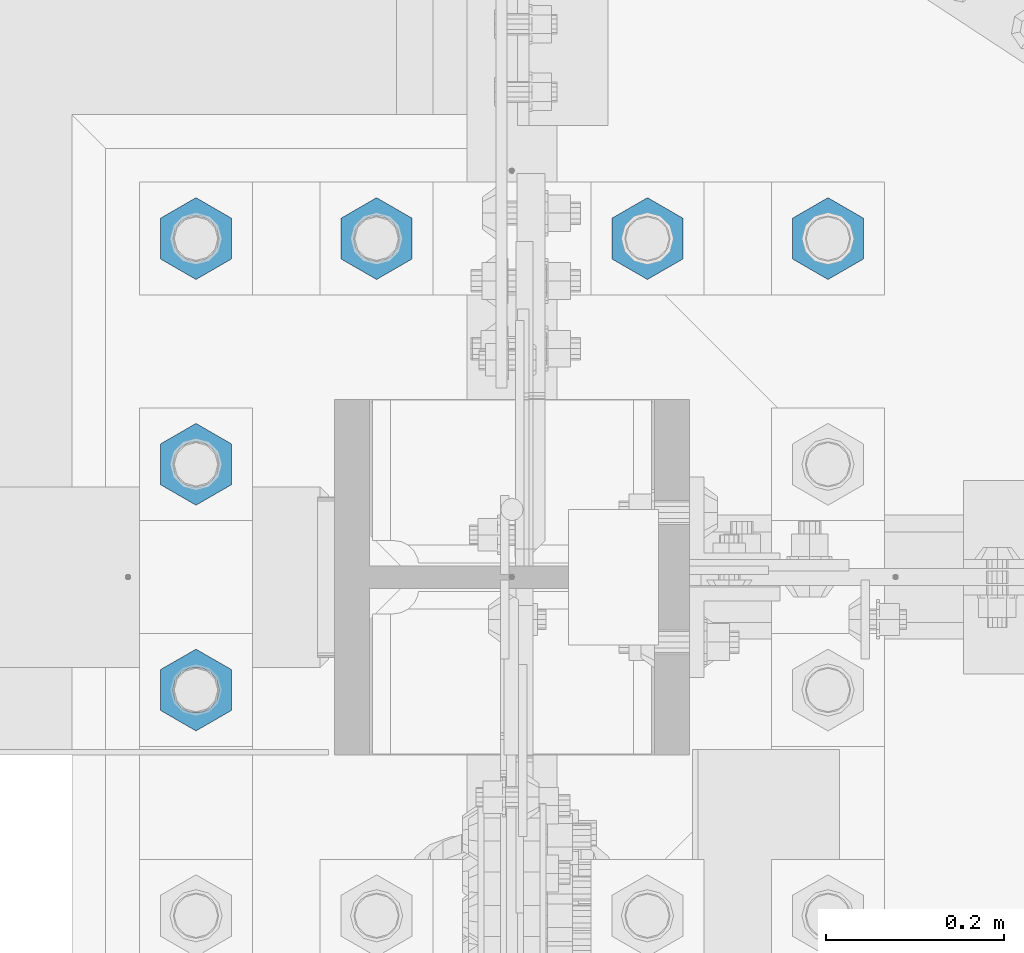
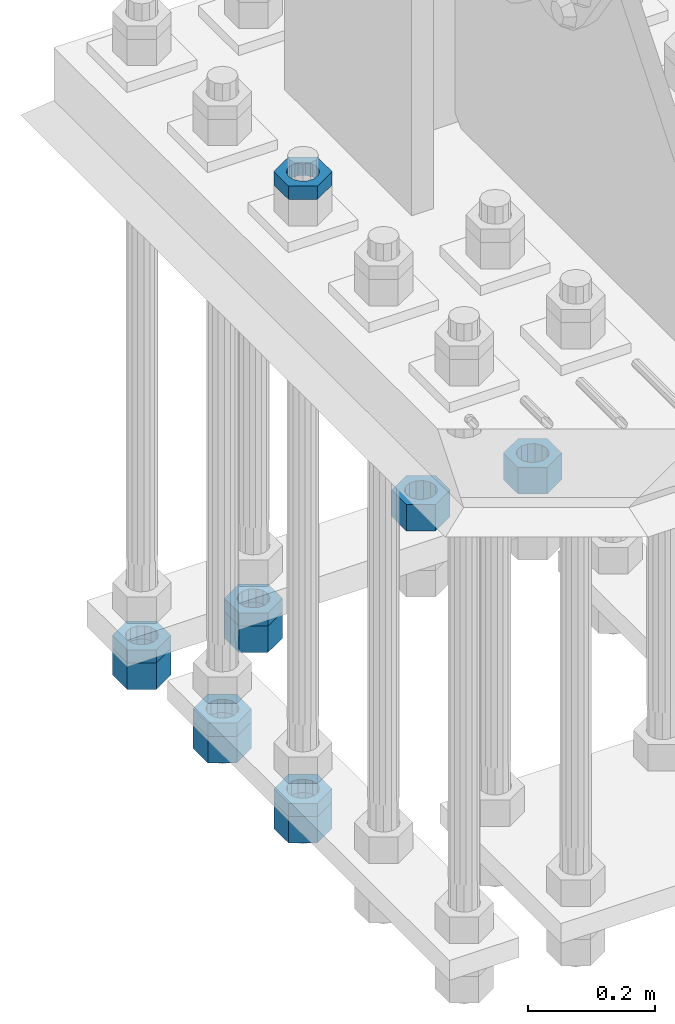
# One storey, part 2215 of 3843: 11 beams, 1 element without a shape of its own.
"""IFC2X3 building model written with IfcOpenShell, lengths in millimetres."""

from ifc_helpers import new_model, si_unit, frame, origin_with_axes, place, context, subcontext, project, spatial, faceted_brep, material, type_object, element, aggregate, save


model = new_model("IFC2X3")

# Units and contexts
model_context = context("Model", 3, precision=1e-05, world=origin_with_axes())
body_context = subcontext(model_context, "Body", "Model", "MODEL_VIEW")
ifc_project = project(units=[si_unit("LENGTHUNIT", "METRE", prefix="MILLI"), si_unit("AREAUNIT", "SQUARE_METRE"), si_unit("VOLUMEUNIT", "CUBIC_METRE"), si_unit("MASSUNIT", "GRAM", prefix="KILO"), si_unit("TIMEUNIT", "SECOND"), si_unit("PLANEANGLEUNIT", "RADIAN"), si_unit("SOLIDANGLEUNIT", "STERADIAN"), si_unit("THERMODYNAMICTEMPERATUREUNIT", "DEGREE_CELSIUS"), si_unit("LUMINOUSINTENSITYUNIT", "LUMEN")], contexts=[model_context])

# Site, building, storey
site_placement = place(None, origin_with_axes())
site = spatial("IfcSite", under=ifc_project, at=site_placement, CompositionType="ELEMENT")
building_placement = place(site_placement, origin_with_axes())
building = spatial("IfcBuilding", under=site, at=building_placement, Name="Undefined", CompositionType="ELEMENT")
storey_placement = place(building_placement, origin_with_axes())
storey = spatial("IfcBuildingStorey", under=building, at=storey_placement, Name="Undefined", CompositionType="ELEMENT", Elevation=0.0)

# Assembly, beams
assembly_placement = place(storey_placement, origin_with_axes())
assembly = element("IfcElementAssembly", 1, at=assembly_placement, inside=storey, Name="TEMPLATE", AssemblyPlace="NOTDEFINED", PredefinedType="RIGID_FRAME")
ifc_material = material(Name="STEEL/A572-50")
beam_type_1 = type_object("IfcBeamType", Name="2_HALF_NUT", PredefinedType="NOTDEFINED")
beam_1_placement = place(assembly_placement, frame((36220.4, 58788.3, 30257.75), z_axis=(1.0, 0.0, 0.0), x_axis=(0.0, 0.0, -1.0)))
beam_1 = element("IfcBeam", 2, at=beam_1_placement, type_object=beam_type_1, material=ifc_material, Name="NUT", ObjectType="2_HALF_NUT", context=body_context, shape_type="Brep", body=[
    faceted_brep([(0.0, -46.0369987487793, 0.0), (0.0, -23.0184993743896, -39.869213104248), (25.4000000000015, -23.0184993743896, -39.869213104248), (25.4000000000015, -46.0369987487793, 0.0), (0.0, 23.0184993743896, -39.869213104248), (25.4000000000015, 23.0184993743896, -39.869213104248), (0.0, 46.0369987487793, 0.0), (25.4000000000015, 46.0369987487793, 0.0), (0.0, 23.0184993743896, 39.869213104248), (25.4000000000015, 23.0184993743896, 39.869213104248), (0.0, -23.0184993743896, 39.869213104248), (25.4000000000015, -23.0184993743896, 39.869213104248), (0.0, 0.0, 26.1940002441406), (0.0, 11.3650617044477, 23.5999013092805), (25.4000000000015, 11.3650617044477, 23.5999013092805), (25.4000000000015, 0.0, 26.1940002441406), (0.0, 20.4791109456419, 16.3316083006721), (25.4000000000015, 20.4791109456419, 16.3316083006721), (0.0, 25.5370200498292, 5.82867859874386), (25.4000000000015, 25.5370200498292, 5.82867859874386), (0.0, 25.5370200498292, -5.82867859874386), (25.4000000000015, 25.5370200498292, -5.82867859874386), (0.0, 20.4791109456419, -16.3316083006721), (25.4000000000015, 20.4791109456419, -16.3316083006721), (0.0, 11.3650617044477, -23.5999013092805), (25.4000000000015, 11.3650617044477, -23.5999013092805), (0.0, 0.0, -26.1940002441406), (25.4000000000015, 0.0, -26.1940002441406), (0.0, -11.3650617044477, -23.5999013092805), (25.4000000000015, -11.3650617044477, -23.5999013092805), (0.0, -20.4791109456419, -16.3316083006721), (25.4000000000015, -20.4791109456419, -16.3316083006721), (0.0, -25.5370200498292, -5.82867859874386), (25.4000000000015, -25.5370200498292, -5.82867859874386), (0.0, -25.5370200498292, 5.82867859874386), (25.4000000000015, -25.5370200498292, 5.82867859874386), (0.0, -20.4791109456419, 16.3316083006721), (25.4000000000015, -20.4791109456419, 16.3316083006721), (0.0, -11.3650617044477, 23.5999013092805), (25.4000000000015, -11.3650617044477, 23.5999013092805)], [[[0, 1, 2, 3]], [[1, 4, 5, 2]], [[4, 6, 7, 5]], [[6, 8, 9, 7]], [[8, 10, 11, 9]], [[10, 0, 3, 11]], [[12, 13, 14, 15]], [[13, 16, 17, 14]], [[16, 18, 19, 17]], [[18, 20, 21, 19]], [[20, 22, 23, 21]], [[22, 24, 25, 23]], [[24, 26, 27, 25]], [[26, 28, 29, 27]], [[28, 30, 31, 29]], [[30, 32, 33, 31]], [[32, 34, 35, 33]], [[34, 36, 37, 35]], [[36, 38, 39, 37]], [[38, 12, 15, 39]], [[5, 7, 9, 11, 3, 2], [17, 19, 21, 23, 25, 27, 29, 31, 33, 35, 37, 39, 15, 14]], [[10, 8, 6, 4, 1, 0], [38, 36, 34, 32, 30, 28, 26, 24, 22, 20, 18, 16, 13, 12]]]),
])
beam_2_placement = place(assembly_placement, frame((36423.6, 59296.3, 29057.6), z_axis=(1.0, 0.0, 0.0), x_axis=(0.0, 0.0, -1.0)))
beam_2 = element("IfcBeam", 3, at=beam_2_placement, type_object=beam_type_1, material=ifc_material, Name="NUT", ObjectType="2_HALF_NUT", context=body_context, shape_type="Brep", body=[
    faceted_brep([(0.0, -46.0369987487793, 0.0), (0.0, -23.0184993743896, -39.869213104248), (25.4000000000015, -23.0184993743896, -39.869213104248), (25.4000000000015, -46.0369987487793, 0.0), (0.0, 23.0184993743896, -39.869213104248), (25.4000000000015, 23.0184993743896, -39.869213104248), (0.0, 46.0369987487793, 0.0), (25.4000000000015, 46.0369987487793, 0.0), (0.0, 23.0184993743896, 39.869213104248), (25.4000000000015, 23.0184993743896, 39.869213104248), (0.0, -23.0184993743896, 39.869213104248), (25.4000000000015, -23.0184993743896, 39.869213104248), (0.0, 0.0, 26.1940002441406), (0.0, 11.3650617044477, 23.5999013092805), (25.4000000000015, 11.3650617044477, 23.5999013092805), (25.4000000000015, 0.0, 26.1940002441406), (0.0, 20.4791109456419, 16.3316083006721), (25.4000000000015, 20.4791109456419, 16.3316083006721), (0.0, 25.5370200498292, 5.82867859874386), (25.4000000000015, 25.5370200498292, 5.82867859874386), (0.0, 25.5370200498292, -5.82867859874386), (25.4000000000015, 25.5370200498292, -5.82867859874386), (0.0, 20.4791109456419, -16.3316083006721), (25.4000000000015, 20.4791109456419, -16.3316083006721), (0.0, 11.3650617044477, -23.5999013092805), (25.4000000000015, 11.3650617044477, -23.5999013092805), (0.0, 0.0, -26.1940002441406), (25.4000000000015, 0.0, -26.1940002441406), (0.0, -11.3650617044477, -23.5999013092805), (25.4000000000015, -11.3650617044477, -23.5999013092805), (0.0, -20.4791109456419, -16.3316083006721), (25.4000000000015, -20.4791109456419, -16.3316083006721), (0.0, -25.5370200498292, -5.82867859874386), (25.4000000000015, -25.5370200498292, -5.82867859874386), (0.0, -25.5370200498292, 5.82867859874386), (25.4000000000015, -25.5370200498292, 5.82867859874386), (0.0, -20.4791109456419, 16.3316083006721), (25.4000000000015, -20.4791109456419, 16.3316083006721), (0.0, -11.3650617044477, 23.5999013092805), (25.4000000000015, -11.3650617044477, 23.5999013092805)], [[[0, 1, 2, 3]], [[1, 4, 5, 2]], [[4, 6, 7, 5]], [[6, 8, 9, 7]], [[8, 10, 11, 9]], [[10, 0, 3, 11]], [[12, 13, 14, 15]], [[13, 16, 17, 14]], [[16, 18, 19, 17]], [[18, 20, 21, 19]], [[20, 22, 23, 21]], [[22, 24, 25, 23]], [[24, 26, 27, 25]], [[26, 28, 29, 27]], [[28, 30, 31, 29]], [[30, 32, 33, 31]], [[32, 34, 35, 33]], [[34, 36, 37, 35]], [[36, 38, 39, 37]], [[38, 12, 15, 39]], [[5, 7, 9, 11, 3, 2], [17, 19, 21, 23, 25, 27, 29, 31, 33, 35, 37, 39, 15, 14]], [[10, 8, 6, 4, 1, 0], [38, 36, 34, 32, 30, 28, 26, 24, 22, 20, 18, 16, 13, 12]]]),
])
beam_3_placement = place(assembly_placement, frame((36220.4, 59296.3, 29057.6), z_axis=(1.0, 0.0, 0.0), x_axis=(0.0, 0.0, -1.0)))
beam_3 = element("IfcBeam", 4, at=beam_3_placement, type_object=beam_type_1, material=ifc_material, Name="NUT", ObjectType="2_HALF_NUT", context=body_context, shape_type="Brep", body=[
    faceted_brep([(0.0, -46.0369987487793, 0.0), (0.0, -23.0184993743896, -39.869213104248), (25.4000000000015, -23.0184993743896, -39.869213104248), (25.4000000000015, -46.0369987487793, 0.0), (0.0, 23.0184993743896, -39.869213104248), (25.4000000000015, 23.0184993743896, -39.869213104248), (0.0, 46.0369987487793, 0.0), (25.4000000000015, 46.0369987487793, 0.0), (0.0, 23.0184993743896, 39.869213104248), (25.4000000000015, 23.0184993743896, 39.869213104248), (0.0, -23.0184993743896, 39.869213104248), (25.4000000000015, -23.0184993743896, 39.869213104248), (0.0, 0.0, 26.1940002441406), (0.0, 11.3650617044477, 23.5999013092805), (25.4000000000015, 11.3650617044477, 23.5999013092805), (25.4000000000015, 0.0, 26.1940002441406), (0.0, 20.4791109456419, 16.3316083006721), (25.4000000000015, 20.4791109456419, 16.3316083006721), (0.0, 25.5370200498292, 5.82867859874386), (25.4000000000015, 25.5370200498292, 5.82867859874386), (0.0, 25.5370200498292, -5.82867859874386), (25.4000000000015, 25.5370200498292, -5.82867859874386), (0.0, 20.4791109456419, -16.3316083006721), (25.4000000000015, 20.4791109456419, -16.3316083006721), (0.0, 11.3650617044477, -23.5999013092805), (25.4000000000015, 11.3650617044477, -23.5999013092805), (0.0, 0.0, -26.1940002441406), (25.4000000000015, 0.0, -26.1940002441406), (0.0, -11.3650617044477, -23.5999013092805), (25.4000000000015, -11.3650617044477, -23.5999013092805), (0.0, -20.4791109456419, -16.3316083006721), (25.4000000000015, -20.4791109456419, -16.3316083006721), (0.0, -25.5370200498292, -5.82867859874386), (25.4000000000015, -25.5370200498292, -5.82867859874386), (0.0, -25.5370200498292, 5.82867859874386), (25.4000000000015, -25.5370200498292, 5.82867859874386), (0.0, -20.4791109456419, 16.3316083006721), (25.4000000000015, -20.4791109456419, 16.3316083006721), (0.0, -11.3650617044477, 23.5999013092805), (25.4000000000015, -11.3650617044477, 23.5999013092805)], [[[0, 1, 2, 3]], [[1, 4, 5, 2]], [[4, 6, 7, 5]], [[6, 8, 9, 7]], [[8, 10, 11, 9]], [[10, 0, 3, 11]], [[12, 13, 14, 15]], [[13, 16, 17, 14]], [[16, 18, 19, 17]], [[18, 20, 21, 19]], [[20, 22, 23, 21]], [[22, 24, 25, 23]], [[24, 26, 27, 25]], [[26, 28, 29, 27]], [[28, 30, 31, 29]], [[30, 32, 33, 31]], [[32, 34, 35, 33]], [[34, 36, 37, 35]], [[36, 38, 39, 37]], [[38, 12, 15, 39]], [[5, 7, 9, 11, 3, 2], [17, 19, 21, 23, 25, 27, 29, 31, 33, 35, 37, 39, 15, 14]], [[10, 8, 6, 4, 1, 0], [38, 36, 34, 32, 30, 28, 26, 24, 22, 20, 18, 16, 13, 12]]]),
])
beam_4_placement = place(assembly_placement, frame((36220.4, 59042.3, 29070.3), z_axis=(1.0, 0.0, 0.0), x_axis=(0.0, 0.0, -1.0)))
beam_4 = element("IfcBeam", 5, at=beam_4_placement, type_object=beam_type_1, material=ifc_material, Name="NUT", ObjectType="2_HALF_NUT", context=body_context, shape_type="Brep", body=[
    faceted_brep([(0.0, -46.0369987487793, 0.0), (0.0, -23.0184993743896, -39.869213104248), (25.4000000000015, -23.0184993743896, -39.869213104248), (25.4000000000015, -46.0369987487793, 0.0), (0.0, 23.0184993743896, -39.869213104248), (25.4000000000015, 23.0184993743896, -39.869213104248), (0.0, 46.0369987487793, 0.0), (25.4000000000015, 46.0369987487793, 0.0), (0.0, 23.0184993743896, 39.869213104248), (25.4000000000015, 23.0184993743896, 39.869213104248), (0.0, -23.0184993743896, 39.869213104248), (25.4000000000015, -23.0184993743896, 39.869213104248), (0.0, 0.0, 26.1940002441406), (0.0, 11.3650617044477, 23.5999013092805), (25.4000000000015, 11.3650617044477, 23.5999013092805), (25.4000000000015, 0.0, 26.1940002441406), (0.0, 20.4791109456419, 16.3316083006721), (25.4000000000015, 20.4791109456419, 16.3316083006721), (0.0, 25.5370200498292, 5.82867859874386), (25.4000000000015, 25.5370200498292, 5.82867859874386), (0.0, 25.5370200498292, -5.82867859874386), (25.4000000000015, 25.5370200498292, -5.82867859874386), (0.0, 20.4791109456419, -16.3316083006721), (25.4000000000015, 20.4791109456419, -16.3316083006721), (0.0, 11.3650617044477, -23.5999013092805), (25.4000000000015, 11.3650617044477, -23.5999013092805), (0.0, 0.0, -26.1940002441406), (25.4000000000015, 0.0, -26.1940002441406), (0.0, -11.3650617044477, -23.5999013092805), (25.4000000000015, -11.3650617044477, -23.5999013092805), (0.0, -20.4791109456419, -16.3316083006721), (25.4000000000015, -20.4791109456419, -16.3316083006721), (0.0, -25.5370200498292, -5.82867859874386), (25.4000000000015, -25.5370200498292, -5.82867859874386), (0.0, -25.5370200498292, 5.82867859874386), (25.4000000000015, -25.5370200498292, 5.82867859874386), (0.0, -20.4791109456419, 16.3316083006721), (25.4000000000015, -20.4791109456419, 16.3316083006721), (0.0, -11.3650617044477, 23.5999013092805), (25.4000000000015, -11.3650617044477, 23.5999013092805)], [[[0, 1, 2, 3]], [[1, 4, 5, 2]], [[4, 6, 7, 5]], [[6, 8, 9, 7]], [[8, 10, 11, 9]], [[10, 0, 3, 11]], [[12, 13, 14, 15]], [[13, 16, 17, 14]], [[16, 18, 19, 17]], [[18, 20, 21, 19]], [[20, 22, 23, 21]], [[22, 24, 25, 23]], [[24, 26, 27, 25]], [[26, 28, 29, 27]], [[28, 30, 31, 29]], [[30, 32, 33, 31]], [[32, 34, 35, 33]], [[34, 36, 37, 35]], [[36, 38, 39, 37]], [[38, 12, 15, 39]], [[5, 7, 9, 11, 3, 2], [17, 19, 21, 23, 25, 27, 29, 31, 33, 35, 37, 39, 15, 14]], [[10, 8, 6, 4, 1, 0], [38, 36, 34, 32, 30, 28, 26, 24, 22, 20, 18, 16, 13, 12]]]),
])
beam_5_placement = place(assembly_placement, frame((36220.4, 58788.3, 29070.3), z_axis=(1.0, 0.0, 0.0), x_axis=(0.0, 0.0, -1.0)))
beam_5 = element("IfcBeam", 6, at=beam_5_placement, type_object=beam_type_1, material=ifc_material, Name="NUT", ObjectType="2_HALF_NUT", context=body_context, shape_type="Brep", body=[
    faceted_brep([(0.0, -46.0369987487793, 0.0), (0.0, -23.0184993743896, -39.869213104248), (25.4000000000015, -23.0184993743896, -39.869213104248), (25.4000000000015, -46.0369987487793, 0.0), (0.0, 23.0184993743896, -39.869213104248), (25.4000000000015, 23.0184993743896, -39.869213104248), (0.0, 46.0369987487793, 0.0), (25.4000000000015, 46.0369987487793, 0.0), (0.0, 23.0184993743896, 39.869213104248), (25.4000000000015, 23.0184993743896, 39.869213104248), (0.0, -23.0184993743896, 39.869213104248), (25.4000000000015, -23.0184993743896, 39.869213104248), (0.0, 0.0, 26.1940002441406), (0.0, 11.3650617044477, 23.5999013092805), (25.4000000000015, 11.3650617044477, 23.5999013092805), (25.4000000000015, 0.0, 26.1940002441406), (0.0, 20.4791109456419, 16.3316083006721), (25.4000000000015, 20.4791109456419, 16.3316083006721), (0.0, 25.5370200498292, 5.82867859874386), (25.4000000000015, 25.5370200498292, 5.82867859874386), (0.0, 25.5370200498292, -5.82867859874386), (25.4000000000015, 25.5370200498292, -5.82867859874386), (0.0, 20.4791109456419, -16.3316083006721), (25.4000000000015, 20.4791109456419, -16.3316083006721), (0.0, 11.3650617044477, -23.5999013092805), (25.4000000000015, 11.3650617044477, -23.5999013092805), (0.0, 0.0, -26.1940002441406), (25.4000000000015, 0.0, -26.1940002441406), (0.0, -11.3650617044477, -23.5999013092805), (25.4000000000015, -11.3650617044477, -23.5999013092805), (0.0, -20.4791109456419, -16.3316083006721), (25.4000000000015, -20.4791109456419, -16.3316083006721), (0.0, -25.5370200498292, -5.82867859874386), (25.4000000000015, -25.5370200498292, -5.82867859874386), (0.0, -25.5370200498292, 5.82867859874386), (25.4000000000015, -25.5370200498292, 5.82867859874386), (0.0, -20.4791109456419, 16.3316083006721), (25.4000000000015, -20.4791109456419, 16.3316083006721), (0.0, -11.3650617044477, 23.5999013092805), (25.4000000000015, -11.3650617044477, 23.5999013092805)], [[[0, 1, 2, 3]], [[1, 4, 5, 2]], [[4, 6, 7, 5]], [[6, 8, 9, 7]], [[8, 10, 11, 9]], [[10, 0, 3, 11]], [[12, 13, 14, 15]], [[13, 16, 17, 14]], [[16, 18, 19, 17]], [[18, 20, 21, 19]], [[20, 22, 23, 21]], [[22, 24, 25, 23]], [[24, 26, 27, 25]], [[26, 28, 29, 27]], [[28, 30, 31, 29]], [[30, 32, 33, 31]], [[32, 34, 35, 33]], [[34, 36, 37, 35]], [[36, 38, 39, 37]], [[38, 12, 15, 39]], [[5, 7, 9, 11, 3, 2], [17, 19, 21, 23, 25, 27, 29, 31, 33, 35, 37, 39, 15, 14]], [[10, 8, 6, 4, 1, 0], [38, 36, 34, 32, 30, 28, 26, 24, 22, 20, 18, 16, 13, 12]]]),
])
beam_type_2 = type_object("IfcBeamType", Name="2_HEAVY_HEX_NUT", PredefinedType="NOTDEFINED")
beam_6_placement = place(assembly_placement, frame((36931.6, 59296.3, 29159.2), z_axis=(1.0, 0.0, 0.0), x_axis=(0.0, 0.0, -1.0)))
beam_6 = element("IfcBeam", 7, at=beam_6_placement, type_object=beam_type_2, material=ifc_material, Name="NUT", ObjectType="2_HEAVY_HEX_NUT", context=body_context, shape_type="Brep", body=[
    faceted_brep([(0.0, -46.0369987487793, 0.0), (0.0, -23.0184993743896, -39.869213104248), (50.7999999999993, -23.0184993743896, -39.869213104248), (50.7999999999993, -46.0369987487793, 0.0), (0.0, 23.0184993743896, -39.869213104248), (50.7999999999993, 23.0184993743896, -39.869213104248), (0.0, 46.0369987487793, 0.0), (50.7999999999993, 46.0369987487793, 0.0), (0.0, 23.0184993743896, 39.869213104248), (50.7999999999993, 23.0184993743896, 39.869213104248), (0.0, -23.0184993743896, 39.869213104248), (50.7999999999993, -23.0184993743896, 39.869213104248), (0.0, 0.0, 26.1940002441406), (0.0, 11.3650617044477, 23.5999013092805), (50.7999999999993, 11.3650617044477, 23.5999013092805), (50.7999999999993, 0.0, 26.1940002441406), (0.0, 20.4791109456419, 16.3316083006721), (50.7999999999993, 20.4791109456419, 16.3316083006721), (0.0, 25.5370200498292, 5.82867859874386), (50.7999999999993, 25.5370200498292, 5.82867859874386), (0.0, 25.5370200498292, -5.82867859874386), (50.7999999999993, 25.5370200498292, -5.82867859874386), (0.0, 20.4791109456419, -16.3316083006721), (50.7999999999993, 20.4791109456419, -16.3316083006721), (0.0, 11.3650617044477, -23.5999013092805), (50.7999999999993, 11.3650617044477, -23.5999013092805), (0.0, 0.0, -26.1940002441406), (50.7999999999993, 0.0, -26.1940002441406), (0.0, -11.3650617044477, -23.5999013092805), (50.7999999999993, -11.3650617044477, -23.5999013092805), (0.0, -20.4791109456419, -16.3316083006721), (50.7999999999993, -20.4791109456419, -16.3316083006721), (0.0, -25.5370200498292, -5.82867859874386), (50.7999999999993, -25.5370200498292, -5.82867859874386), (0.0, -25.5370200498292, 5.82867859874386), (50.7999999999993, -25.5370200498292, 5.82867859874386), (0.0, -20.4791109456419, 16.3316083006721), (50.7999999999993, -20.4791109456419, 16.3316083006721), (0.0, -11.3650617044477, 23.5999013092805), (50.7999999999993, -11.3650617044477, 23.5999013092805)], [[[0, 1, 2, 3]], [[1, 4, 5, 2]], [[4, 6, 7, 5]], [[6, 8, 9, 7]], [[8, 10, 11, 9]], [[10, 0, 3, 11]], [[12, 13, 14, 15]], [[13, 16, 17, 14]], [[16, 18, 19, 17]], [[18, 20, 21, 19]], [[20, 22, 23, 21]], [[22, 24, 25, 23]], [[24, 26, 27, 25]], [[26, 28, 29, 27]], [[28, 30, 31, 29]], [[30, 32, 33, 31]], [[32, 34, 35, 33]], [[34, 36, 37, 35]], [[36, 38, 39, 37]], [[38, 12, 15, 39]], [[5, 7, 9, 11, 3, 2], [17, 19, 21, 23, 25, 27, 29, 31, 33, 35, 37, 39, 15, 14]], [[10, 8, 6, 4, 1, 0], [38, 36, 34, 32, 30, 28, 26, 24, 22, 20, 18, 16, 13, 12]]]),
])
beam_7_placement = place(assembly_placement, frame((36728.4, 59296.3, 29159.2), z_axis=(1.0, 0.0, 0.0), x_axis=(0.0, 0.0, -1.0)))
beam_7 = element("IfcBeam", 8, at=beam_7_placement, type_object=beam_type_2, material=ifc_material, Name="NUT", ObjectType="2_HEAVY_HEX_NUT", context=body_context, shape_type="Brep", body=[
    faceted_brep([(0.0, -46.0369987487793, 0.0), (0.0, -23.0184993743896, -39.869213104248), (50.7999999999993, -23.0184993743896, -39.869213104248), (50.7999999999993, -46.0369987487793, 0.0), (0.0, 23.0184993743896, -39.869213104248), (50.7999999999993, 23.0184993743896, -39.869213104248), (0.0, 46.0369987487793, 0.0), (50.7999999999993, 46.0369987487793, 0.0), (0.0, 23.0184993743896, 39.869213104248), (50.7999999999993, 23.0184993743896, 39.869213104248), (0.0, -23.0184993743896, 39.869213104248), (50.7999999999993, -23.0184993743896, 39.869213104248), (0.0, 0.0, 26.1940002441406), (0.0, 11.3650617044477, 23.5999013092805), (50.7999999999993, 11.3650617044477, 23.5999013092805), (50.7999999999993, 0.0, 26.1940002441406), (0.0, 20.4791109456419, 16.3316083006721), (50.7999999999993, 20.4791109456419, 16.3316083006721), (0.0, 25.5370200498292, 5.82867859874386), (50.7999999999993, 25.5370200498292, 5.82867859874386), (0.0, 25.5370200498292, -5.82867859874386), (50.7999999999993, 25.5370200498292, -5.82867859874386), (0.0, 20.4791109456419, -16.3316083006721), (50.7999999999993, 20.4791109456419, -16.3316083006721), (0.0, 11.3650617044477, -23.5999013092805), (50.7999999999993, 11.3650617044477, -23.5999013092805), (0.0, 0.0, -26.1940002441406), (50.7999999999993, 0.0, -26.1940002441406), (0.0, -11.3650617044477, -23.5999013092805), (50.7999999999993, -11.3650617044477, -23.5999013092805), (0.0, -20.4791109456419, -16.3316083006721), (50.7999999999993, -20.4791109456419, -16.3316083006721), (0.0, -25.5370200498292, -5.82867859874386), (50.7999999999993, -25.5370200498292, -5.82867859874386), (0.0, -25.5370200498292, 5.82867859874386), (50.7999999999993, -25.5370200498292, 5.82867859874386), (0.0, -20.4791109456419, 16.3316083006721), (50.7999999999993, -20.4791109456419, 16.3316083006721), (0.0, -11.3650617044477, 23.5999013092805), (50.7999999999993, -11.3650617044477, 23.5999013092805)], [[[0, 1, 2, 3]], [[1, 4, 5, 2]], [[4, 6, 7, 5]], [[6, 8, 9, 7]], [[8, 10, 11, 9]], [[10, 0, 3, 11]], [[12, 13, 14, 15]], [[13, 16, 17, 14]], [[16, 18, 19, 17]], [[18, 20, 21, 19]], [[20, 22, 23, 21]], [[22, 24, 25, 23]], [[24, 26, 27, 25]], [[26, 28, 29, 27]], [[28, 30, 31, 29]], [[30, 32, 33, 31]], [[32, 34, 35, 33]], [[34, 36, 37, 35]], [[36, 38, 39, 37]], [[38, 12, 15, 39]], [[5, 7, 9, 11, 3, 2], [17, 19, 21, 23, 25, 27, 29, 31, 33, 35, 37, 39, 15, 14]], [[10, 8, 6, 4, 1, 0], [38, 36, 34, 32, 30, 28, 26, 24, 22, 20, 18, 16, 13, 12]]]),
])
beam_8_placement = place(assembly_placement, frame((36423.6, 59296.3, 29032.2), z_axis=(1.0, 0.0, 0.0), x_axis=(0.0, 0.0, -1.0)))
beam_8 = element("IfcBeam", 9, at=beam_8_placement, type_object=beam_type_2, material=ifc_material, Name="NUT", ObjectType="2_HEAVY_HEX_NUT", context=body_context, shape_type="Brep", body=[
    faceted_brep([(0.0, -46.0369987487793, 0.0), (0.0, -23.0184993743896, -39.869213104248), (50.7999999999993, -23.0184993743896, -39.869213104248), (50.7999999999993, -46.0369987487793, 0.0), (0.0, 23.0184993743896, -39.869213104248), (50.7999999999993, 23.0184993743896, -39.869213104248), (0.0, 46.0369987487793, 0.0), (50.7999999999993, 46.0369987487793, 0.0), (0.0, 23.0184993743896, 39.869213104248), (50.7999999999993, 23.0184993743896, 39.869213104248), (0.0, -23.0184993743896, 39.869213104248), (50.7999999999993, -23.0184993743896, 39.869213104248), (0.0, 0.0, 26.1940002441406), (0.0, 11.3650617044477, 23.5999013092805), (50.7999999999993, 11.3650617044477, 23.5999013092805), (50.7999999999993, 0.0, 26.1940002441406), (0.0, 20.4791109456419, 16.3316083006721), (50.7999999999993, 20.4791109456419, 16.3316083006721), (0.0, 25.5370200498292, 5.82867859874386), (50.7999999999993, 25.5370200498292, 5.82867859874386), (0.0, 25.5370200498292, -5.82867859874386), (50.7999999999993, 25.5370200498292, -5.82867859874386), (0.0, 20.4791109456419, -16.3316083006721), (50.7999999999993, 20.4791109456419, -16.3316083006721), (0.0, 11.3650617044477, -23.5999013092805), (50.7999999999993, 11.3650617044477, -23.5999013092805), (0.0, 0.0, -26.1940002441406), (50.7999999999993, 0.0, -26.1940002441406), (0.0, -11.3650617044477, -23.5999013092805), (50.7999999999993, -11.3650617044477, -23.5999013092805), (0.0, -20.4791109456419, -16.3316083006721), (50.7999999999993, -20.4791109456419, -16.3316083006721), (0.0, -25.5370200498292, -5.82867859874386), (50.7999999999993, -25.5370200498292, -5.82867859874386), (0.0, -25.5370200498292, 5.82867859874386), (50.7999999999993, -25.5370200498292, 5.82867859874386), (0.0, -20.4791109456419, 16.3316083006721), (50.7999999999993, -20.4791109456419, 16.3316083006721), (0.0, -11.3650617044477, 23.5999013092805), (50.7999999999993, -11.3650617044477, 23.5999013092805)], [[[0, 1, 2, 3]], [[1, 4, 5, 2]], [[4, 6, 7, 5]], [[6, 8, 9, 7]], [[8, 10, 11, 9]], [[10, 0, 3, 11]], [[12, 13, 14, 15]], [[13, 16, 17, 14]], [[16, 18, 19, 17]], [[18, 20, 21, 19]], [[20, 22, 23, 21]], [[22, 24, 25, 23]], [[24, 26, 27, 25]], [[26, 28, 29, 27]], [[28, 30, 31, 29]], [[30, 32, 33, 31]], [[32, 34, 35, 33]], [[34, 36, 37, 35]], [[36, 38, 39, 37]], [[38, 12, 15, 39]], [[5, 7, 9, 11, 3, 2], [17, 19, 21, 23, 25, 27, 29, 31, 33, 35, 37, 39, 15, 14]], [[10, 8, 6, 4, 1, 0], [38, 36, 34, 32, 30, 28, 26, 24, 22, 20, 18, 16, 13, 12]]]),
])
beam_9_placement = place(assembly_placement, frame((36220.4, 59296.3, 29032.2), z_axis=(1.0, 0.0, 0.0), x_axis=(0.0, 0.0, -1.0)))
beam_9 = element("IfcBeam", 10, at=beam_9_placement, type_object=beam_type_2, material=ifc_material, Name="NUT", ObjectType="2_HEAVY_HEX_NUT", context=body_context, shape_type="Brep", body=[
    faceted_brep([(0.0, -46.0369987487793, 0.0), (0.0, -23.0184993743896, -39.869213104248), (50.7999999999993, -23.0184993743896, -39.869213104248), (50.7999999999993, -46.0369987487793, 0.0), (0.0, 23.0184993743896, -39.869213104248), (50.7999999999993, 23.0184993743896, -39.869213104248), (0.0, 46.0369987487793, 0.0), (50.7999999999993, 46.0369987487793, 0.0), (0.0, 23.0184993743896, 39.869213104248), (50.7999999999993, 23.0184993743896, 39.869213104248), (0.0, -23.0184993743896, 39.869213104248), (50.7999999999993, -23.0184993743896, 39.869213104248), (0.0, 0.0, 26.1940002441406), (0.0, 11.3650617044477, 23.5999013092805), (50.7999999999993, 11.3650617044477, 23.5999013092805), (50.7999999999993, 0.0, 26.1940002441406), (0.0, 20.4791109456419, 16.3316083006721), (50.7999999999993, 20.4791109456419, 16.3316083006721), (0.0, 25.5370200498292, 5.82867859874386), (50.7999999999993, 25.5370200498292, 5.82867859874386), (0.0, 25.5370200498292, -5.82867859874386), (50.7999999999993, 25.5370200498292, -5.82867859874386), (0.0, 20.4791109456419, -16.3316083006721), (50.7999999999993, 20.4791109456419, -16.3316083006721), (0.0, 11.3650617044477, -23.5999013092805), (50.7999999999993, 11.3650617044477, -23.5999013092805), (0.0, 0.0, -26.1940002441406), (50.7999999999993, 0.0, -26.1940002441406), (0.0, -11.3650617044477, -23.5999013092805), (50.7999999999993, -11.3650617044477, -23.5999013092805), (0.0, -20.4791109456419, -16.3316083006721), (50.7999999999993, -20.4791109456419, -16.3316083006721), (0.0, -25.5370200498292, -5.82867859874386), (50.7999999999993, -25.5370200498292, -5.82867859874386), (0.0, -25.5370200498292, 5.82867859874386), (50.7999999999993, -25.5370200498292, 5.82867859874386), (0.0, -20.4791109456419, 16.3316083006721), (50.7999999999993, -20.4791109456419, 16.3316083006721), (0.0, -11.3650617044477, 23.5999013092805), (50.7999999999993, -11.3650617044477, 23.5999013092805)], [[[0, 1, 2, 3]], [[1, 4, 5, 2]], [[4, 6, 7, 5]], [[6, 8, 9, 7]], [[8, 10, 11, 9]], [[10, 0, 3, 11]], [[12, 13, 14, 15]], [[13, 16, 17, 14]], [[16, 18, 19, 17]], [[18, 20, 21, 19]], [[20, 22, 23, 21]], [[22, 24, 25, 23]], [[24, 26, 27, 25]], [[26, 28, 29, 27]], [[28, 30, 31, 29]], [[30, 32, 33, 31]], [[32, 34, 35, 33]], [[34, 36, 37, 35]], [[36, 38, 39, 37]], [[38, 12, 15, 39]], [[5, 7, 9, 11, 3, 2], [17, 19, 21, 23, 25, 27, 29, 31, 33, 35, 37, 39, 15, 14]], [[10, 8, 6, 4, 1, 0], [38, 36, 34, 32, 30, 28, 26, 24, 22, 20, 18, 16, 13, 12]]]),
])
beam_10_placement = place(assembly_placement, frame((36220.4, 59042.3, 29044.9), z_axis=(1.0, 0.0, 0.0), x_axis=(0.0, 0.0, -1.0)))
beam_10 = element("IfcBeam", 11, at=beam_10_placement, type_object=beam_type_2, material=ifc_material, Name="NUT", ObjectType="2_HEAVY_HEX_NUT", context=body_context, shape_type="Brep", body=[
    faceted_brep([(0.0, -46.0369987487793, 0.0), (0.0, -23.0184993743896, -39.869213104248), (50.7999999999993, -23.0184993743896, -39.869213104248), (50.7999999999993, -46.0369987487793, 0.0), (0.0, 23.0184993743896, -39.869213104248), (50.7999999999993, 23.0184993743896, -39.869213104248), (0.0, 46.0369987487793, 0.0), (50.7999999999993, 46.0369987487793, 0.0), (0.0, 23.0184993743896, 39.869213104248), (50.7999999999993, 23.0184993743896, 39.869213104248), (0.0, -23.0184993743896, 39.869213104248), (50.7999999999993, -23.0184993743896, 39.869213104248), (0.0, 0.0, 26.1940002441406), (0.0, 11.3650617044477, 23.5999013092805), (50.7999999999993, 11.3650617044477, 23.5999013092805), (50.7999999999993, 0.0, 26.1940002441406), (0.0, 20.4791109456419, 16.3316083006721), (50.7999999999993, 20.4791109456419, 16.3316083006721), (0.0, 25.5370200498292, 5.82867859874386), (50.7999999999993, 25.5370200498292, 5.82867859874386), (0.0, 25.5370200498292, -5.82867859874386), (50.7999999999993, 25.5370200498292, -5.82867859874386), (0.0, 20.4791109456419, -16.3316083006721), (50.7999999999993, 20.4791109456419, -16.3316083006721), (0.0, 11.3650617044477, -23.5999013092805), (50.7999999999993, 11.3650617044477, -23.5999013092805), (0.0, 0.0, -26.1940002441406), (50.7999999999993, 0.0, -26.1940002441406), (0.0, -11.3650617044477, -23.5999013092805), (50.7999999999993, -11.3650617044477, -23.5999013092805), (0.0, -20.4791109456419, -16.3316083006721), (50.7999999999993, -20.4791109456419, -16.3316083006721), (0.0, -25.5370200498292, -5.82867859874386), (50.7999999999993, -25.5370200498292, -5.82867859874386), (0.0, -25.5370200498292, 5.82867859874386), (50.7999999999993, -25.5370200498292, 5.82867859874386), (0.0, -20.4791109456419, 16.3316083006721), (50.7999999999993, -20.4791109456419, 16.3316083006721), (0.0, -11.3650617044477, 23.5999013092805), (50.7999999999993, -11.3650617044477, 23.5999013092805)], [[[0, 1, 2, 3]], [[1, 4, 5, 2]], [[4, 6, 7, 5]], [[6, 8, 9, 7]], [[8, 10, 11, 9]], [[10, 0, 3, 11]], [[12, 13, 14, 15]], [[13, 16, 17, 14]], [[16, 18, 19, 17]], [[18, 20, 21, 19]], [[20, 22, 23, 21]], [[22, 24, 25, 23]], [[24, 26, 27, 25]], [[26, 28, 29, 27]], [[28, 30, 31, 29]], [[30, 32, 33, 31]], [[32, 34, 35, 33]], [[34, 36, 37, 35]], [[36, 38, 39, 37]], [[38, 12, 15, 39]], [[5, 7, 9, 11, 3, 2], [17, 19, 21, 23, 25, 27, 29, 31, 33, 35, 37, 39, 15, 14]], [[10, 8, 6, 4, 1, 0], [38, 36, 34, 32, 30, 28, 26, 24, 22, 20, 18, 16, 13, 12]]]),
])
beam_11_placement = place(assembly_placement, frame((36220.4, 58788.3, 29044.9), z_axis=(1.0, 0.0, 0.0), x_axis=(0.0, 0.0, -1.0)))
beam_11 = element("IfcBeam", 12, at=beam_11_placement, type_object=beam_type_2, material=ifc_material, Name="NUT", ObjectType="2_HEAVY_HEX_NUT", context=body_context, shape_type="Brep", body=[
    faceted_brep([(0.0, -46.0369987487793, 0.0), (0.0, -23.0184993743896, -39.869213104248), (50.7999999999993, -23.0184993743896, -39.869213104248), (50.7999999999993, -46.0369987487793, 0.0), (0.0, 23.0184993743896, -39.869213104248), (50.7999999999993, 23.0184993743896, -39.869213104248), (0.0, 46.0369987487793, 0.0), (50.7999999999993, 46.0369987487793, 0.0), (0.0, 23.0184993743896, 39.869213104248), (50.7999999999993, 23.0184993743896, 39.869213104248), (0.0, -23.0184993743896, 39.869213104248), (50.7999999999993, -23.0184993743896, 39.869213104248), (0.0, 0.0, 26.1940002441406), (0.0, 11.3650617044477, 23.5999013092805), (50.7999999999993, 11.3650617044477, 23.5999013092805), (50.7999999999993, 0.0, 26.1940002441406), (0.0, 20.4791109456419, 16.3316083006721), (50.7999999999993, 20.4791109456419, 16.3316083006721), (0.0, 25.5370200498292, 5.82867859874386), (50.7999999999993, 25.5370200498292, 5.82867859874386), (0.0, 25.5370200498292, -5.82867859874386), (50.7999999999993, 25.5370200498292, -5.82867859874386), (0.0, 20.4791109456419, -16.3316083006721), (50.7999999999993, 20.4791109456419, -16.3316083006721), (0.0, 11.3650617044477, -23.5999013092805), (50.7999999999993, 11.3650617044477, -23.5999013092805), (0.0, 0.0, -26.1940002441406), (50.7999999999993, 0.0, -26.1940002441406), (0.0, -11.3650617044477, -23.5999013092805), (50.7999999999993, -11.3650617044477, -23.5999013092805), (0.0, -20.4791109456419, -16.3316083006721), (50.7999999999993, -20.4791109456419, -16.3316083006721), (0.0, -25.5370200498292, -5.82867859874386), (50.7999999999993, -25.5370200498292, -5.82867859874386), (0.0, -25.5370200498292, 5.82867859874386), (50.7999999999993, -25.5370200498292, 5.82867859874386), (0.0, -20.4791109456419, 16.3316083006721), (50.7999999999993, -20.4791109456419, 16.3316083006721), (0.0, -11.3650617044477, 23.5999013092805), (50.7999999999993, -11.3650617044477, 23.5999013092805)], [[[0, 1, 2, 3]], [[1, 4, 5, 2]], [[4, 6, 7, 5]], [[6, 8, 9, 7]], [[8, 10, 11, 9]], [[10, 0, 3, 11]], [[12, 13, 14, 15]], [[13, 16, 17, 14]], [[16, 18, 19, 17]], [[18, 20, 21, 19]], [[20, 22, 23, 21]], [[22, 24, 25, 23]], [[24, 26, 27, 25]], [[26, 28, 29, 27]], [[28, 30, 31, 29]], [[30, 32, 33, 31]], [[32, 34, 35, 33]], [[34, 36, 37, 35]], [[36, 38, 39, 37]], [[38, 12, 15, 39]], [[5, 7, 9, 11, 3, 2], [17, 19, 21, 23, 25, 27, 29, 31, 33, 35, 37, 39, 15, 14]], [[10, 8, 6, 4, 1, 0], [38, 36, 34, 32, 30, 28, 26, 24, 22, 20, 18, 16, 13, 12]]]),
])
aggregate(assembly, [beam_6, beam_7, beam_1, beam_8, beam_2, beam_9, beam_3, beam_10, beam_11, beam_4, beam_5])

save(model, "model.ifc")
